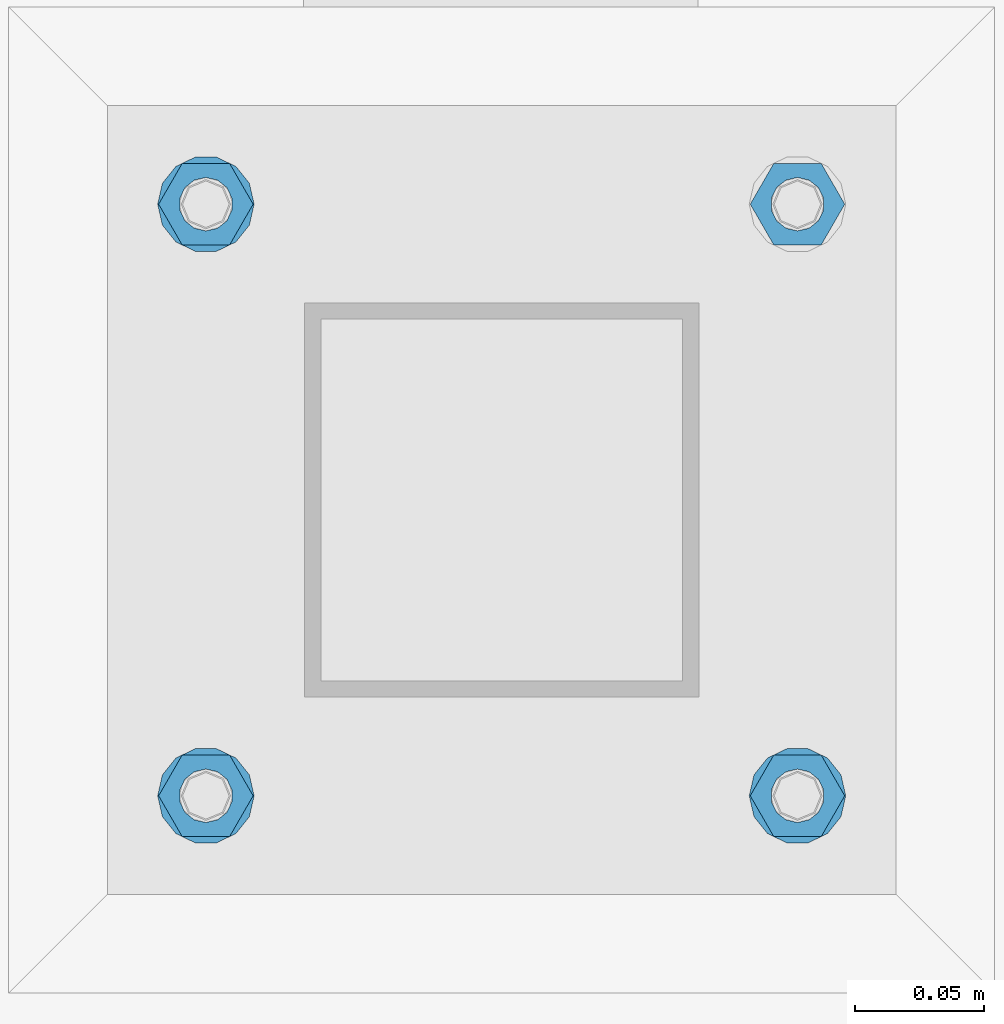
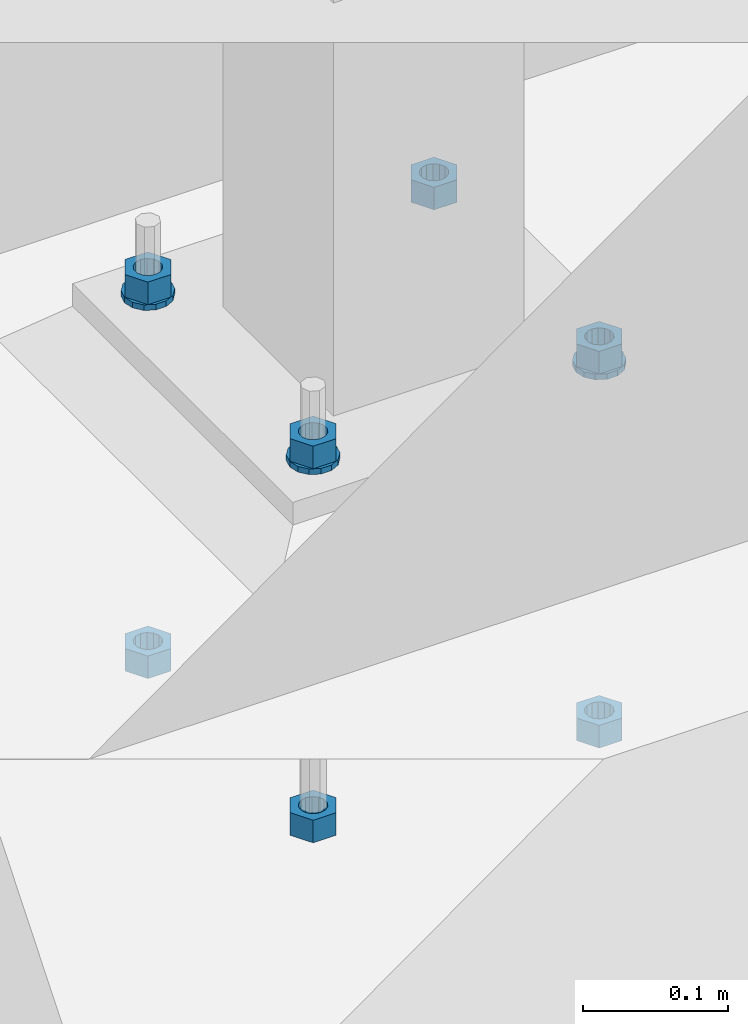
# One storey, part 957 of 1179: 10 beams, 1 element without a shape of its own.
"""IFC2X3 building model written with IfcOpenShell, lengths in millimetres."""

import ifcopenshell
import ifcopenshell.guid

model = None  # the IFC model being written
_history = None  # IfcOwnerHistory: only IFC2X3 demands one
_inside = {}  # id of a spatial element -> (the spatial element, [elements in it])
_under = {}  # id of a project, library or spatial element -> (it, [spatial elements below it])
_declared = {}  # id of a project -> (the project, [libraries it declares])
_typed = {}  # id of a type object -> (the type object, [elements of that type])
_made_of = {}  # id of a material, layer set ... -> (it, [elements and type objects made of it])


def new_model(schema):
    """Start an empty IFC model of exactly this schema.

    Asked for "IFC4X3", IfcOpenShell would pick the latest addendum, in which some entities
    have other attributes; the version numbers below select the first issue.
    IFC2X3 requires an IfcOwnerHistory on every rooted entity: one is made here for all.
    """
    global model, _history
    if schema == "IFC4X3":
        model = ifcopenshell.file(schema_version=(4, 3, 0, 0))
    else:
        model = ifcopenshell.file(schema=schema)
    _inside.clear()
    _under.clear()
    _declared.clear()
    _typed.clear()
    _made_of.clear()
    _history = None
    if model.schema == "IFC2X3":
        org = make("IfcOrganization", Name="unknown")
        user = make(
            "IfcPersonAndOrganization",
            ThePerson=make("IfcPerson", FamilyName="unknown"),
            TheOrganization=org,
        )
        app = make(
            "IfcApplication",
            ApplicationDeveloper=org,
            Version="unknown",
            ApplicationFullName="unknown",
            ApplicationIdentifier="unknown",
        )
        _history = make(
            "IfcOwnerHistory",
            OwningUser=user,
            OwningApplication=app,
            ChangeAction="ADDED",
            CreationDate=0,
        )
    return model


def make(cls, **values):
    """One entity of the class cls with the attributes given. An attribute that is None is left unset."""
    return model.create_entity(
        cls, **{name: value for name, value in values.items() if value is not None}
    )


def rooted(cls, **values):
    """An entity with a GlobalId (a new one), such as an element, a storey or a relation."""
    return make(cls, GlobalId=ifcopenshell.guid.new(), OwnerHistory=_history, **values)


def si_unit(unit_type, name, prefix=None):
    """IfcSIUnit, for example si_unit("LENGTHUNIT", "METRE", prefix="MILLI")."""
    return make("IfcSIUnit", UnitType=unit_type, Prefix=prefix, Name=name)


def assignment(units):
    """IfcUnitAssignment: the units of a project."""
    return None if units is None else make("IfcUnitAssignment", Units=units)


def point(xyz):
    """IfcCartesianPoint."""
    return None if xyz is None else make("IfcCartesianPoint", Coordinates=xyz)


def direction(xyz):
    """IfcDirection."""
    return None if xyz is None else make("IfcDirection", DirectionRatios=xyz)


def frame(location, z_axis=None, x_axis=None):
    """IfcAxis2Placement3D, a coordinate frame: its origin and axes. An axis left out is left unset."""
    return make(
        "IfcAxis2Placement3D",
        Location=point(location),
        Axis=direction(z_axis),
        RefDirection=direction(x_axis),
    )


def origin_with_axes():
    """The frame at (0, 0, 0) with the z axis (0, 0, 1) and the x axis (1, 0, 0) written out."""
    return frame((0.0, 0.0, 0.0), z_axis=(0.0, 0.0, 1.0), x_axis=(1.0, 0.0, 0.0))


def place(relative_to, where):
    """IfcLocalPlacement: puts the frame where relative to a parent placement (None: the world)."""
    return make(
        "IfcLocalPlacement", PlacementRelTo=relative_to, RelativePlacement=where
    )


def context(
    kind, dimensions, precision=None, world=None, true_north=None, identifier=None
):
    """IfcGeometricRepresentationContext, for example the 3D "Model" context."""
    return make(
        "IfcGeometricRepresentationContext",
        ContextIdentifier=identifier,
        ContextType=kind,
        CoordinateSpaceDimension=dimensions,
        Precision=precision,
        WorldCoordinateSystem=world,
        TrueNorth=true_north,
    )


def subcontext(parent, identifier, kind, view, scale=None):
    """IfcGeometricRepresentationSubContext, for example "Body" below "Model"."""
    return make(
        "IfcGeometricRepresentationSubContext",
        ContextIdentifier=identifier,
        ContextType=kind,
        ParentContext=parent,
        TargetScale=scale,
        TargetView=view,
    )


def project(units=None, contexts=None):
    """IfcProject with its units and contexts."""
    return rooted(
        "IfcProject",
        Name="project",
        RepresentationContexts=contexts,
        UnitsInContext=assignment(units),
    )


def spatial(cls, under=None, at=None, **own):
    """A site, building, storey or space (cls), placed at a placement, below another one or the project."""
    s = rooted(cls, ObjectPlacement=at, **own)
    if under is not None:
        _under.setdefault(under.id(), (under, []))[1].append(s)
    return s


def faces_of(points, faces, orient=None, outer=None):
    """IfcFace entities. A face is a list of loops; a loop is a list of indices into points, from 0.

    orient and outer hold one flag for each loop. By default every Orientation is true, the
    first loop of a face is its IfcFaceOuterBound and the others are IfcFaceBound.
    """
    made = []
    for i, loops in enumerate(faces):
        bounds = []
        for j, loop in enumerate(loops):
            is_outer = j == 0 if outer is None else outer[i][j]
            bounds.append(
                make(
                    "IfcFaceOuterBound" if is_outer else "IfcFaceBound",
                    Bound=make("IfcPolyLoop", Polygon=[points[k] for k in loop]),
                    Orientation=True if orient is None else orient[i][j],
                )
            )
        made.append(make("IfcFace", Bounds=bounds))
    return made


def faceted_brep(points, faces, orient=None, outer=None, voids=None):
    """IfcFacetedBrep: a solid bounded by flat faces; with voids (closed shells), ...WithVoids."""
    shared = [point(p) for p in points]
    hull = make("IfcClosedShell", CfsFaces=faces_of(shared, faces, orient, outer))
    if voids is None:
        return make("IfcFacetedBrep", Outer=hull)
    return make(
        "IfcFacetedBrepWithVoids",
        Outer=hull,
        Voids=[
            make(cls, CfsFaces=faces_of(shared, fs, o, b)) for cls, fs, o, b in voids
        ],
    )


def shape(context_of_items, identifier, shape_type, items):
    """IfcShapeRepresentation: the items that make up one representation, for example the "Body"."""
    return make(
        "IfcShapeRepresentation",
        ContextOfItems=context_of_items,
        RepresentationIdentifier=identifier,
        RepresentationType=shape_type,
        Items=items,
    )


def material(Name=None, Category=None):
    """IfcMaterial."""
    return make("IfcMaterial", Name=Name, Category=Category)


def made_of(thing, what):
    """Note that an element or type object is made of a material, layer set ...; save() writes the relation."""
    if what is not None:
        _made_of.setdefault(what.id(), (what, []))[1].append(thing)
    return thing


def type_object(cls, material=None, **own):
    """A type object (cls), such as IfcWallType, which elements share."""
    return made_of(rooted(cls, **own), material)


def element(
    cls,
    number,
    at=None,
    inside=None,
    cuts=None,
    type_object=None,
    material=None,
    context=None,
    identifier="Body",
    shape_type=None,
    held_by="IfcProductDefinitionShape",
    body=None,
    shapes=None,
    **own,
):
    """One element of the class cls, such as IfcWall. Its Tag is "e" and its number.

    at: its placement. inside: the storey or other place that contains it. cuts: it is an
    opening in that element (IfcRelVoidsElement). A single representation is given by context,
    identifier, shape_type and body (its items); several are given by shapes. held_by: the class
    of the entity that holds the representations. save() writes the other relations.
    """
    e = rooted(cls, Tag="e%d" % number, ObjectPlacement=at, **own)
    if body is not None:
        shapes = [shape(context, identifier, shape_type, body)]
    if shapes is not None:
        e.Representation = make(held_by, Representations=shapes)
    if inside is not None:
        _inside.setdefault(inside.id(), (inside, []))[1].append(e)
    if cuts is not None:
        rooted(
            "IfcRelVoidsElement", RelatingBuildingElement=cuts, RelatedOpeningElement=e
        )
    if type_object is not None:
        _typed.setdefault(type_object.id(), (type_object, []))[1].append(e)
    return made_of(e, material)


def aggregate(whole, parts):
    """IfcRelAggregates: a whole, such as a stair, and the parts it consists of."""
    return rooted("IfcRelAggregates", RelatingObject=whole, RelatedObjects=parts)


def save(model, path):
    """Write the relations noted so far, then the file.

    IfcRelAggregates (storeys below a building ...), IfcRelContainedInSpatialStructure (elements
    in a storey), IfcRelDefinesByType, IfcRelAssociatesMaterial and IfcRelDeclares: one each for
    every whole, place, type object, material and project.
    """
    for whole, parts in _under.values():
        aggregate(whole, parts)
    for where, things in _inside.values():
        rooted(
            "IfcRelContainedInSpatialStructure",
            RelatedElements=things,
            RelatingStructure=where,
        )
    for kind, things in _typed.values():
        rooted("IfcRelDefinesByType", RelatedObjects=things, RelatingType=kind)
    for what, things in _made_of.values():
        rooted("IfcRelAssociatesMaterial", RelatedObjects=things, RelatingMaterial=what)
    for by, libraries in _declared.values():
        rooted("IfcRelDeclares", RelatingContext=by, RelatedDefinitions=libraries)
    model.write(path)


model = new_model("IFC2X3")

# Units and contexts
model_context = context("Model", 3, precision=1e-05, world=origin_with_axes())
body_context = subcontext(model_context, "Body", "Model", "MODEL_VIEW")
ifc_project = project(units=[si_unit("LENGTHUNIT", "METRE", prefix="MILLI"), si_unit("AREAUNIT", "SQUARE_METRE"), si_unit("VOLUMEUNIT", "CUBIC_METRE"), si_unit("MASSUNIT", "GRAM", prefix="KILO"), si_unit("TIMEUNIT", "SECOND"), si_unit("PLANEANGLEUNIT", "RADIAN"), si_unit("SOLIDANGLEUNIT", "STERADIAN"), si_unit("THERMODYNAMICTEMPERATUREUNIT", "DEGREE_CELSIUS"), si_unit("LUMINOUSINTENSITYUNIT", "LUMEN")], contexts=[model_context])

# Site, building, storey
site_placement = place(None, origin_with_axes())
site = spatial("IfcSite", under=ifc_project, at=site_placement, CompositionType="ELEMENT")
building_placement = place(site_placement, origin_with_axes())
building = spatial("IfcBuilding", under=site, at=building_placement, Name="Undefined", CompositionType="ELEMENT")
storey_placement = place(building_placement, origin_with_axes())
storey = spatial("IfcBuildingStorey", under=building, at=storey_placement, Name="Undefined", CompositionType="ELEMENT", Elevation=0.0)

# Assembly, beams
assembly_placement = place(storey_placement, origin_with_axes())
assembly = element("IfcElementAssembly", 1, at=assembly_placement, inside=storey, Name="TEMPLATE", AssemblyPlace="NOTDEFINED", PredefinedType="RIGID_FRAME")
ifc_material = material(Name="STEEL/A36")
beam_type_1 = type_object("IfcBeamType", Name="3/4_HEAVY_HEX_NUT", PredefinedType="NOTDEFINED")
beam_1_placement = place(assembly_placement, frame((30111.7, 2120.9, -731.8375), z_axis=(0.0, -1.0, 0.0), x_axis=(0.0, 0.0, -1.0)))
beam_1 = element("IfcBeam", 2, at=beam_1_placement, type_object=beam_type_1, material=ifc_material, Name="NUT", ObjectType="3/4_HEAVY_HEX_NUT", context=body_context, shape_type="Brep", body=[
    faceted_brep([(0.0, -18.2600002288818, 0.0), (0.0, -9.13000011444092, -15.8100004196167), (19.0499999999865, -9.13000011444092, -15.8100004196167), (19.0499999999865, -18.2600002288818, 0.0), (0.0, 9.13000011444092, -15.8100004196167), (19.0499999999865, 9.13000011444092, -15.8100004196167), (0.0, 18.2600002288818, 0.0), (19.0499999999865, 18.2600002288818, 0.0), (0.0, 9.13000011444092, 15.8100004196167), (19.0499999999865, 9.13000011444092, 15.8100004196167), (0.0, -9.13000011444092, 15.8100004196167), (19.0499999999865, -9.13000011444092, 15.8100004196167), (0.0, 0.0, 10.3199996948242), (0.0, 4.47768005528246, 9.29799844179979), (19.0499999999865, 4.47768005528246, 9.29799844179979), (19.0499999999865, 0.0, 10.3199996948242), (0.0, 8.068500660474, 6.43441456490837), (19.0499999999865, 8.068500660474, 6.43441456490837), (0.0, 10.0612557561919, 2.29641597052068), (19.0499999999865, 10.0612557561919, 2.29641597052068), (0.0, 10.0612557561919, -2.29641597052068), (19.0499999999865, 10.0612557561919, -2.29641597052068), (0.0, 8.068500660474, -6.43441456490837), (19.0499999999865, 8.068500660474, -6.43441456490837), (0.0, 4.47768005528246, -9.29799844179979), (19.0499999999865, 4.47768005528246, -9.29799844179979), (0.0, 0.0, -10.3199996948242), (19.0499999999865, 0.0, -10.3199996948242), (0.0, -4.47768005528246, -9.29799844179979), (19.0499999999865, -4.47768005528246, -9.29799844179979), (0.0, -8.068500660474, -6.43441456490837), (19.0499999999865, -8.068500660474, -6.43441456490837), (0.0, -10.0612557561919, -2.29641597052068), (19.0499999999865, -10.0612557561919, -2.29641597052068), (0.0, -10.0612557561919, 2.29641597052068), (19.0499999999865, -10.0612557561919, 2.29641597052068), (0.0, -8.068500660474, 6.43441456490837), (19.0499999999865, -8.068500660474, 6.43441456490837), (0.0, -4.47768005528246, 9.29799844179979), (19.0499999999865, -4.47768005528246, 9.29799844179979)], [[[0, 1, 2, 3]], [[1, 4, 5, 2]], [[4, 6, 7, 5]], [[6, 8, 9, 7]], [[8, 10, 11, 9]], [[10, 0, 3, 11]], [[12, 13, 14, 15]], [[13, 16, 17, 14]], [[16, 18, 19, 17]], [[18, 20, 21, 19]], [[20, 22, 23, 21]], [[22, 24, 25, 23]], [[24, 26, 27, 25]], [[26, 28, 29, 27]], [[28, 30, 31, 29]], [[30, 32, 33, 31]], [[32, 34, 35, 33]], [[34, 36, 37, 35]], [[36, 38, 39, 37]], [[38, 12, 15, 39]], [[5, 7, 9, 11, 3, 2], [17, 19, 21, 23, 25, 27, 29, 31, 33, 35, 37, 39, 15, 14]], [[10, 8, 6, 4, 1, 0], [38, 36, 34, 32, 30, 28, 26, 24, 22, 20, 18, 16, 13, 12]]]),
])
beam_2_placement = place(assembly_placement, frame((30111.7, 2120.9, -1047.75), z_axis=(0.0, -1.0, 0.0), x_axis=(0.0, 0.0, -1.0)))
beam_2 = element("IfcBeam", 3, at=beam_2_placement, type_object=beam_type_1, material=ifc_material, Name="NUT", ObjectType="3/4_HEAVY_HEX_NUT", context=body_context, shape_type="Brep", body=[
    faceted_brep([(0.0, -18.2600002288818, 0.0), (0.0, -9.13000011444092, -15.8100004196167), (19.0499999999865, -9.13000011444092, -15.8100004196167), (19.0499999999865, -18.2600002288818, 0.0), (0.0, 9.13000011444092, -15.8100004196167), (19.0499999999865, 9.13000011444092, -15.8100004196167), (0.0, 18.2600002288818, 0.0), (19.0499999999865, 18.2600002288818, 0.0), (0.0, 9.13000011444092, 15.8100004196167), (19.0499999999865, 9.13000011444092, 15.8100004196167), (0.0, -9.13000011444092, 15.8100004196167), (19.0499999999865, -9.13000011444092, 15.8100004196167), (0.0, 0.0, 10.3199996948242), (0.0, 4.47768005528246, 9.29799844179979), (19.0499999999865, 4.47768005528246, 9.29799844179979), (19.0499999999865, 0.0, 10.3199996948242), (0.0, 8.068500660474, 6.43441456490837), (19.0499999999865, 8.068500660474, 6.43441456490837), (0.0, 10.0612557561919, 2.29641597052068), (19.0499999999865, 10.0612557561919, 2.29641597052068), (0.0, 10.0612557561919, -2.29641597052068), (19.0499999999865, 10.0612557561919, -2.29641597052068), (0.0, 8.068500660474, -6.43441456490837), (19.0499999999865, 8.068500660474, -6.43441456490837), (0.0, 4.47768005528246, -9.29799844179979), (19.0499999999865, 4.47768005528246, -9.29799844179979), (0.0, 0.0, -10.3199996948242), (19.0499999999865, 0.0, -10.3199996948242), (0.0, -4.47768005528246, -9.29799844179979), (19.0499999999865, -4.47768005528246, -9.29799844179979), (0.0, -8.068500660474, -6.43441456490837), (19.0499999999865, -8.068500660474, -6.43441456490837), (0.0, -10.0612557561919, -2.29641597052068), (19.0499999999865, -10.0612557561919, -2.29641597052068), (0.0, -10.0612557561919, 2.29641597052068), (19.0499999999865, -10.0612557561919, 2.29641597052068), (0.0, -8.068500660474, 6.43441456490837), (19.0499999999865, -8.068500660474, 6.43441456490837), (0.0, -4.47768005528246, 9.29799844179979), (19.0499999999865, -4.47768005528246, 9.29799844179979)], [[[0, 1, 2, 3]], [[1, 4, 5, 2]], [[4, 6, 7, 5]], [[6, 8, 9, 7]], [[8, 10, 11, 9]], [[10, 0, 3, 11]], [[12, 13, 14, 15]], [[13, 16, 17, 14]], [[16, 18, 19, 17]], [[18, 20, 21, 19]], [[20, 22, 23, 21]], [[22, 24, 25, 23]], [[24, 26, 27, 25]], [[26, 28, 29, 27]], [[28, 30, 31, 29]], [[30, 32, 33, 31]], [[32, 34, 35, 33]], [[34, 36, 37, 35]], [[36, 38, 39, 37]], [[38, 12, 15, 39]], [[5, 7, 9, 11, 3, 2], [17, 19, 21, 23, 25, 27, 29, 31, 33, 35, 37, 39, 15, 14]], [[10, 8, 6, 4, 1, 0], [38, 36, 34, 32, 30, 28, 26, 24, 22, 20, 18, 16, 13, 12]]]),
])
beam_3_placement = place(assembly_placement, frame((30340.3, 2120.9, -731.8375), z_axis=(0.0, 1.0, 0.0), x_axis=(0.0, 0.0, -1.0)))
beam_3 = element("IfcBeam", 4, at=beam_3_placement, type_object=beam_type_1, material=ifc_material, Name="NUT", ObjectType="3/4_HEAVY_HEX_NUT", context=body_context, shape_type="Brep", body=[
    faceted_brep([(0.0, -18.2600002288818, 0.0), (0.0, -9.13000011444092, -15.8100004196167), (19.0499999999865, -9.13000011444092, -15.8100004196167), (19.0499999999865, -18.2600002288818, 0.0), (0.0, 9.13000011444092, -15.8100004196167), (19.0499999999865, 9.13000011444092, -15.8100004196167), (0.0, 18.2600002288818, 0.0), (19.0499999999865, 18.2600002288818, 0.0), (0.0, 9.13000011444092, 15.8100004196167), (19.0499999999865, 9.13000011444092, 15.8100004196167), (0.0, -9.13000011444092, 15.8100004196167), (19.0499999999865, -9.13000011444092, 15.8100004196167), (0.0, 0.0, 10.3199996948242), (0.0, 4.47768005528246, 9.29799844179979), (19.0499999999865, 4.47768005528246, 9.29799844179979), (19.0499999999865, 0.0, 10.3199996948242), (0.0, 8.068500660474, 6.43441456490837), (19.0499999999865, 8.068500660474, 6.43441456490837), (0.0, 10.0612557561919, 2.29641597052068), (19.0499999999865, 10.0612557561919, 2.29641597052068), (0.0, 10.0612557561919, -2.29641597052068), (19.0499999999865, 10.0612557561919, -2.29641597052068), (0.0, 8.068500660474, -6.43441456490837), (19.0499999999865, 8.068500660474, -6.43441456490837), (0.0, 4.47768005528246, -9.29799844179979), (19.0499999999865, 4.47768005528246, -9.29799844179979), (0.0, 0.0, -10.3199996948242), (19.0499999999865, 0.0, -10.3199996948242), (0.0, -4.47768005528246, -9.29799844179979), (19.0499999999865, -4.47768005528246, -9.29799844179979), (0.0, -8.068500660474, -6.43441456490837), (19.0499999999865, -8.068500660474, -6.43441456490837), (0.0, -10.0612557561919, -2.29641597052068), (19.0499999999865, -10.0612557561919, -2.29641597052068), (0.0, -10.0612557561919, 2.29641597052068), (19.0499999999865, -10.0612557561919, 2.29641597052068), (0.0, -8.068500660474, 6.43441456490837), (19.0499999999865, -8.068500660474, 6.43441456490837), (0.0, -4.47768005528246, 9.29799844179979), (19.0499999999865, -4.47768005528246, 9.29799844179979)], [[[0, 1, 2, 3]], [[1, 4, 5, 2]], [[4, 6, 7, 5]], [[6, 8, 9, 7]], [[8, 10, 11, 9]], [[10, 0, 3, 11]], [[12, 13, 14, 15]], [[13, 16, 17, 14]], [[16, 18, 19, 17]], [[18, 20, 21, 19]], [[20, 22, 23, 21]], [[22, 24, 25, 23]], [[24, 26, 27, 25]], [[26, 28, 29, 27]], [[28, 30, 31, 29]], [[30, 32, 33, 31]], [[32, 34, 35, 33]], [[34, 36, 37, 35]], [[36, 38, 39, 37]], [[38, 12, 15, 39]], [[5, 7, 9, 11, 3, 2], [17, 19, 21, 23, 25, 27, 29, 31, 33, 35, 37, 39, 15, 14]], [[10, 8, 6, 4, 1, 0], [38, 36, 34, 32, 30, 28, 26, 24, 22, 20, 18, 16, 13, 12]]]),
])
beam_4_placement = place(assembly_placement, frame((30340.3, 2120.9, -1047.75), z_axis=(0.0, 1.0, 0.0), x_axis=(0.0, 0.0, -1.0)))
beam_4 = element("IfcBeam", 5, at=beam_4_placement, type_object=beam_type_1, material=ifc_material, Name="NUT", ObjectType="3/4_HEAVY_HEX_NUT", context=body_context, shape_type="Brep", body=[
    faceted_brep([(0.0, -18.2600002288818, 0.0), (0.0, -9.13000011444092, -15.8100004196167), (19.0499999999865, -9.13000011444092, -15.8100004196167), (19.0499999999865, -18.2600002288818, 0.0), (0.0, 9.13000011444092, -15.8100004196167), (19.0499999999865, 9.13000011444092, -15.8100004196167), (0.0, 18.2600002288818, 0.0), (19.0499999999865, 18.2600002288818, 0.0), (0.0, 9.13000011444092, 15.8100004196167), (19.0499999999865, 9.13000011444092, 15.8100004196167), (0.0, -9.13000011444092, 15.8100004196167), (19.0499999999865, -9.13000011444092, 15.8100004196167), (0.0, 0.0, 10.3199996948242), (0.0, 4.47768005528246, 9.29799844179979), (19.0499999999865, 4.47768005528246, 9.29799844179979), (19.0499999999865, 0.0, 10.3199996948242), (0.0, 8.068500660474, 6.43441456490837), (19.0499999999865, 8.068500660474, 6.43441456490837), (0.0, 10.0612557561919, 2.29641597052068), (19.0499999999865, 10.0612557561919, 2.29641597052068), (0.0, 10.0612557561919, -2.29641597052068), (19.0499999999865, 10.0612557561919, -2.29641597052068), (0.0, 8.068500660474, -6.43441456490837), (19.0499999999865, 8.068500660474, -6.43441456490837), (0.0, 4.47768005528246, -9.29799844179979), (19.0499999999865, 4.47768005528246, -9.29799844179979), (0.0, 0.0, -10.3199996948242), (19.0499999999865, 0.0, -10.3199996948242), (0.0, -4.47768005528246, -9.29799844179979), (19.0499999999865, -4.47768005528246, -9.29799844179979), (0.0, -8.068500660474, -6.43441456490837), (19.0499999999865, -8.068500660474, -6.43441456490837), (0.0, -10.0612557561919, -2.29641597052068), (19.0499999999865, -10.0612557561919, -2.29641597052068), (0.0, -10.0612557561919, 2.29641597052068), (19.0499999999865, -10.0612557561919, 2.29641597052068), (0.0, -8.068500660474, 6.43441456490837), (19.0499999999865, -8.068500660474, 6.43441456490837), (0.0, -4.47768005528246, 9.29799844179979), (19.0499999999865, -4.47768005528246, 9.29799844179979)], [[[0, 1, 2, 3]], [[1, 4, 5, 2]], [[4, 6, 7, 5]], [[6, 8, 9, 7]], [[8, 10, 11, 9]], [[10, 0, 3, 11]], [[12, 13, 14, 15]], [[13, 16, 17, 14]], [[16, 18, 19, 17]], [[18, 20, 21, 19]], [[20, 22, 23, 21]], [[22, 24, 25, 23]], [[24, 26, 27, 25]], [[26, 28, 29, 27]], [[28, 30, 31, 29]], [[30, 32, 33, 31]], [[32, 34, 35, 33]], [[34, 36, 37, 35]], [[36, 38, 39, 37]], [[38, 12, 15, 39]], [[5, 7, 9, 11, 3, 2], [17, 19, 21, 23, 25, 27, 29, 31, 33, 35, 37, 39, 15, 14]], [[10, 8, 6, 4, 1, 0], [38, 36, 34, 32, 30, 28, 26, 24, 22, 20, 18, 16, 13, 12]]]),
])
beam_5_placement = place(assembly_placement, frame((30111.7, 2349.5, -731.8375), z_axis=(0.0, -1.0, 0.0), x_axis=(0.0, 0.0, -1.0)))
beam_5 = element("IfcBeam", 6, at=beam_5_placement, type_object=beam_type_1, material=ifc_material, Name="NUT", ObjectType="3/4_HEAVY_HEX_NUT", context=body_context, shape_type="Brep", body=[
    faceted_brep([(0.0, -18.2600002288818, 0.0), (0.0, -9.13000011444092, -15.8100004196167), (19.0499999999865, -9.13000011444092, -15.8100004196167), (19.0499999999865, -18.2600002288818, 0.0), (0.0, 9.13000011444092, -15.8100004196167), (19.0499999999865, 9.13000011444092, -15.8100004196167), (0.0, 18.2600002288818, 0.0), (19.0499999999865, 18.2600002288818, 0.0), (0.0, 9.13000011444092, 15.8100004196167), (19.0499999999865, 9.13000011444092, 15.8100004196167), (0.0, -9.13000011444092, 15.8100004196167), (19.0499999999865, -9.13000011444092, 15.8100004196167), (0.0, 0.0, 10.3199996948242), (0.0, 4.47768005528246, 9.29799844179979), (19.0499999999865, 4.47768005528246, 9.29799844179979), (19.0499999999865, 0.0, 10.3199996948242), (0.0, 8.068500660474, 6.43441456490837), (19.0499999999865, 8.068500660474, 6.43441456490837), (0.0, 10.0612557561919, 2.29641597052068), (19.0499999999865, 10.0612557561919, 2.29641597052068), (0.0, 10.0612557561919, -2.29641597052068), (19.0499999999865, 10.0612557561919, -2.29641597052068), (0.0, 8.068500660474, -6.43441456490837), (19.0499999999865, 8.068500660474, -6.43441456490837), (0.0, 4.47768005528246, -9.29799844179979), (19.0499999999865, 4.47768005528246, -9.29799844179979), (0.0, 0.0, -10.3199996948242), (19.0499999999865, 0.0, -10.3199996948242), (0.0, -4.47768005528246, -9.29799844179979), (19.0499999999865, -4.47768005528246, -9.29799844179979), (0.0, -8.068500660474, -6.43441456490837), (19.0499999999865, -8.068500660474, -6.43441456490837), (0.0, -10.0612557561919, -2.29641597052068), (19.0499999999865, -10.0612557561919, -2.29641597052068), (0.0, -10.0612557561919, 2.29641597052068), (19.0499999999865, -10.0612557561919, 2.29641597052068), (0.0, -8.068500660474, 6.43441456490837), (19.0499999999865, -8.068500660474, 6.43441456490837), (0.0, -4.47768005528246, 9.29799844179979), (19.0499999999865, -4.47768005528246, 9.29799844179979)], [[[0, 1, 2, 3]], [[1, 4, 5, 2]], [[4, 6, 7, 5]], [[6, 8, 9, 7]], [[8, 10, 11, 9]], [[10, 0, 3, 11]], [[12, 13, 14, 15]], [[13, 16, 17, 14]], [[16, 18, 19, 17]], [[18, 20, 21, 19]], [[20, 22, 23, 21]], [[22, 24, 25, 23]], [[24, 26, 27, 25]], [[26, 28, 29, 27]], [[28, 30, 31, 29]], [[30, 32, 33, 31]], [[32, 34, 35, 33]], [[34, 36, 37, 35]], [[36, 38, 39, 37]], [[38, 12, 15, 39]], [[5, 7, 9, 11, 3, 2], [17, 19, 21, 23, 25, 27, 29, 31, 33, 35, 37, 39, 15, 14]], [[10, 8, 6, 4, 1, 0], [38, 36, 34, 32, 30, 28, 26, 24, 22, 20, 18, 16, 13, 12]]]),
])
beam_6_placement = place(assembly_placement, frame((30111.7, 2349.5, -1047.75), z_axis=(0.0, -1.0, 0.0), x_axis=(0.0, 0.0, -1.0)))
beam_6 = element("IfcBeam", 7, at=beam_6_placement, type_object=beam_type_1, material=ifc_material, Name="NUT", ObjectType="3/4_HEAVY_HEX_NUT", context=body_context, shape_type="Brep", body=[
    faceted_brep([(0.0, -18.2600002288818, 0.0), (0.0, -9.13000011444092, -15.8100004196167), (19.0499999999865, -9.13000011444092, -15.8100004196167), (19.0499999999865, -18.2600002288818, 0.0), (0.0, 9.13000011444092, -15.8100004196167), (19.0499999999865, 9.13000011444092, -15.8100004196167), (0.0, 18.2600002288818, 0.0), (19.0499999999865, 18.2600002288818, 0.0), (0.0, 9.13000011444092, 15.8100004196167), (19.0499999999865, 9.13000011444092, 15.8100004196167), (0.0, -9.13000011444092, 15.8100004196167), (19.0499999999865, -9.13000011444092, 15.8100004196167), (0.0, 0.0, 10.3199996948242), (0.0, 4.47768005528246, 9.29799844179979), (19.0499999999865, 4.47768005528246, 9.29799844179979), (19.0499999999865, 0.0, 10.3199996948242), (0.0, 8.068500660474, 6.43441456490837), (19.0499999999865, 8.068500660474, 6.43441456490837), (0.0, 10.0612557561919, 2.29641597052068), (19.0499999999865, 10.0612557561919, 2.29641597052068), (0.0, 10.0612557561919, -2.29641597052068), (19.0499999999865, 10.0612557561919, -2.29641597052068), (0.0, 8.068500660474, -6.43441456490837), (19.0499999999865, 8.068500660474, -6.43441456490837), (0.0, 4.47768005528246, -9.29799844179979), (19.0499999999865, 4.47768005528246, -9.29799844179979), (0.0, 0.0, -10.3199996948242), (19.0499999999865, 0.0, -10.3199996948242), (0.0, -4.47768005528246, -9.29799844179979), (19.0499999999865, -4.47768005528246, -9.29799844179979), (0.0, -8.068500660474, -6.43441456490837), (19.0499999999865, -8.068500660474, -6.43441456490837), (0.0, -10.0612557561919, -2.29641597052068), (19.0499999999865, -10.0612557561919, -2.29641597052068), (0.0, -10.0612557561919, 2.29641597052068), (19.0499999999865, -10.0612557561919, 2.29641597052068), (0.0, -8.068500660474, 6.43441456490837), (19.0499999999865, -8.068500660474, 6.43441456490837), (0.0, -4.47768005528246, 9.29799844179979), (19.0499999999865, -4.47768005528246, 9.29799844179979)], [[[0, 1, 2, 3]], [[1, 4, 5, 2]], [[4, 6, 7, 5]], [[6, 8, 9, 7]], [[8, 10, 11, 9]], [[10, 0, 3, 11]], [[12, 13, 14, 15]], [[13, 16, 17, 14]], [[16, 18, 19, 17]], [[18, 20, 21, 19]], [[20, 22, 23, 21]], [[22, 24, 25, 23]], [[24, 26, 27, 25]], [[26, 28, 29, 27]], [[28, 30, 31, 29]], [[30, 32, 33, 31]], [[32, 34, 35, 33]], [[34, 36, 37, 35]], [[36, 38, 39, 37]], [[38, 12, 15, 39]], [[5, 7, 9, 11, 3, 2], [17, 19, 21, 23, 25, 27, 29, 31, 33, 35, 37, 39, 15, 14]], [[10, 8, 6, 4, 1, 0], [38, 36, 34, 32, 30, 28, 26, 24, 22, 20, 18, 16, 13, 12]]]),
])
beam_7_placement = place(assembly_placement, frame((30340.3, 2349.5, -731.8375), z_axis=(0.0, 1.0, 0.0), x_axis=(0.0, 0.0, -1.0)))
beam_7 = element("IfcBeam", 8, at=beam_7_placement, type_object=beam_type_1, material=ifc_material, Name="NUT", ObjectType="3/4_HEAVY_HEX_NUT", context=body_context, shape_type="Brep", body=[
    faceted_brep([(0.0, -18.2600002288818, 0.0), (0.0, -9.13000011444092, -15.8100004196167), (19.0499999999865, -9.13000011444092, -15.8100004196167), (19.0499999999865, -18.2600002288818, 0.0), (0.0, 9.13000011444092, -15.8100004196167), (19.0499999999865, 9.13000011444092, -15.8100004196167), (0.0, 18.2600002288818, 0.0), (19.0499999999865, 18.2600002288818, 0.0), (0.0, 9.13000011444092, 15.8100004196167), (19.0499999999865, 9.13000011444092, 15.8100004196167), (0.0, -9.13000011444092, 15.8100004196167), (19.0499999999865, -9.13000011444092, 15.8100004196167), (0.0, 0.0, 10.3199996948242), (0.0, 4.47768005528246, 9.29799844179979), (19.0499999999865, 4.47768005528246, 9.29799844179979), (19.0499999999865, 0.0, 10.3199996948242), (0.0, 8.068500660474, 6.43441456490837), (19.0499999999865, 8.068500660474, 6.43441456490837), (0.0, 10.0612557561919, 2.29641597052068), (19.0499999999865, 10.0612557561919, 2.29641597052068), (0.0, 10.0612557561919, -2.29641597052068), (19.0499999999865, 10.0612557561919, -2.29641597052068), (0.0, 8.068500660474, -6.43441456490837), (19.0499999999865, 8.068500660474, -6.43441456490837), (0.0, 4.47768005528246, -9.29799844179979), (19.0499999999865, 4.47768005528246, -9.29799844179979), (0.0, 0.0, -10.3199996948242), (19.0499999999865, 0.0, -10.3199996948242), (0.0, -4.47768005528246, -9.29799844179979), (19.0499999999865, -4.47768005528246, -9.29799844179979), (0.0, -8.068500660474, -6.43441456490837), (19.0499999999865, -8.068500660474, -6.43441456490837), (0.0, -10.0612557561919, -2.29641597052068), (19.0499999999865, -10.0612557561919, -2.29641597052068), (0.0, -10.0612557561919, 2.29641597052068), (19.0499999999865, -10.0612557561919, 2.29641597052068), (0.0, -8.068500660474, 6.43441456490837), (19.0499999999865, -8.068500660474, 6.43441456490837), (0.0, -4.47768005528246, 9.29799844179979), (19.0499999999865, -4.47768005528246, 9.29799844179979)], [[[0, 1, 2, 3]], [[1, 4, 5, 2]], [[4, 6, 7, 5]], [[6, 8, 9, 7]], [[8, 10, 11, 9]], [[10, 0, 3, 11]], [[12, 13, 14, 15]], [[13, 16, 17, 14]], [[16, 18, 19, 17]], [[18, 20, 21, 19]], [[20, 22, 23, 21]], [[22, 24, 25, 23]], [[24, 26, 27, 25]], [[26, 28, 29, 27]], [[28, 30, 31, 29]], [[30, 32, 33, 31]], [[32, 34, 35, 33]], [[34, 36, 37, 35]], [[36, 38, 39, 37]], [[38, 12, 15, 39]], [[5, 7, 9, 11, 3, 2], [17, 19, 21, 23, 25, 27, 29, 31, 33, 35, 37, 39, 15, 14]], [[10, 8, 6, 4, 1, 0], [38, 36, 34, 32, 30, 28, 26, 24, 22, 20, 18, 16, 13, 12]]]),
])
beam_type_2 = type_object("IfcBeamType", Name="3/4_WASHER", PredefinedType="NOTDEFINED")
beam_8_placement = place(assembly_placement, frame((30111.7, 2120.9, -750.8875), z_axis=(0.0, -1.0, 0.0), x_axis=(0.0, 0.0, -1.0)))
beam_8 = element("IfcBeam", 9, at=beam_8_placement, type_object=beam_type_2, material=ifc_material, Name="WASHER", ObjectType="3/4_WASHER", context=body_context, shape_type="Brep", body=[
    faceted_brep([(0.0, -18.6499996185303, 0.0), (0.0, -16.8030690426895, -8.09193156902893), (4.76249999999993, -16.8030690426895, -8.09193156902893), (4.76249999999993, -18.6499996185303, 0.0), (0.0, -11.6280845668225, -14.5811568497838), (4.76249999999993, -11.6280845668225, -14.5811568497838), (0.0, -4.15001533339819, -18.1824051902859), (4.76249999999993, -4.15001533339819, -18.1824051902859), (0.0, 4.15001533339819, -18.1824051902859), (4.76249999999993, 4.15001533339819, -18.1824051902859), (0.0, 11.6280845668225, -14.5811568497838), (4.76249999999993, 11.6280845668225, -14.5811568497838), (0.0, 16.8030690426895, -8.09193156902893), (4.76249999999993, 16.8030690426895, -8.09193156902893), (0.0, 18.6499996185303, 0.0), (4.76249999999993, 18.6499996185303, 0.0), (0.0, 16.8030690426895, 8.09193156902893), (4.76249999999993, 16.8030690426895, 8.09193156902893), (0.0, 11.6280845668225, 14.5811568497838), (4.76249999999993, 11.6280845668225, 14.5811568497838), (0.0, 4.15001533339819, 18.1824051902859), (4.76249999999993, 4.15001533339819, 18.1824051902859), (0.0, -4.15001533339819, 18.1824051902859), (4.76249999999993, -4.15001533339819, 18.1824051902859), (0.0, -11.6280845668225, 14.5811568497838), (4.76249999999993, -11.6280845668225, 14.5811568497838), (0.0, -16.8030690426895, 8.09193156902893), (4.76249999999993, -16.8030690426895, 8.09193156902893), (0.0, 0.0, 10.3199996948242), (0.0, 4.47768005528246, 9.29799844179979), (4.76249999999993, 4.47768005527905, 9.29799844179888), (4.76249999999993, 0.0, 10.3199996948242), (0.0, 8.068500660474, 6.43441456490837), (4.76249999999993, 8.06850066047627, 6.43441456490837), (0.0, 10.0612557561919, 2.29641597052068), (4.76249999999993, 10.0612557561908, 2.29641597052114), (0.0, 10.0612557561919, -2.29641597052068), (4.76249999999993, 10.0612557561908, -2.29641597052114), (0.0, 8.068500660474, -6.43441456490837), (4.76249999999993, 8.06850066047627, -6.43441456490791), (0.0, 4.47768005528246, -9.29799844179979), (4.76249999999993, 4.47768005527905, -9.29799844179888), (0.0, 0.0, -10.3199996948242), (4.76249999999993, 0.0, -10.3199996948242), (0.0, -4.47768005528246, -9.29799844179979), (4.76249999999993, -4.47768005527905, -9.29799844179888), (0.0, -8.068500660474, -6.43441456490837), (4.76249999999993, -8.06850066047627, -6.43441456490837), (0.0, -10.0612557561919, -2.29641597052068), (4.76249999999993, -10.0612557561908, -2.29641597052114), (0.0, -10.0612557561919, 2.29641597052068), (4.76249999999993, -10.0612557561908, 2.29641597052114), (0.0, -8.068500660474, 6.43441456490837), (4.76249999999993, -8.06850066047627, 6.43441456490791), (0.0, -4.47768005528246, 9.29799844179979), (4.76249999999993, -4.47768005527905, 9.29799844179888)], [[[0, 1, 2, 3]], [[1, 4, 5, 2]], [[4, 6, 7, 5]], [[6, 8, 9, 7]], [[8, 10, 11, 9]], [[10, 12, 13, 11]], [[12, 14, 15, 13]], [[14, 16, 17, 15]], [[16, 18, 19, 17]], [[18, 20, 21, 19]], [[20, 22, 23, 21]], [[22, 24, 25, 23]], [[24, 26, 27, 25]], [[26, 0, 3, 27]], [[28, 29, 30, 31]], [[29, 32, 33, 30]], [[32, 34, 35, 33]], [[34, 36, 37, 35]], [[36, 38, 39, 37]], [[38, 40, 41, 39]], [[40, 42, 43, 41]], [[42, 44, 45, 43]], [[44, 46, 47, 45]], [[46, 48, 49, 47]], [[48, 50, 51, 49]], [[50, 52, 53, 51]], [[52, 54, 55, 53]], [[54, 28, 31, 55]], [[5, 7, 9, 11, 13, 15, 17, 19, 21, 23, 25, 27, 3, 2], [33, 35, 37, 39, 41, 43, 45, 47, 49, 51, 53, 55, 31, 30]], [[26, 24, 22, 20, 18, 16, 14, 12, 10, 8, 6, 4, 1, 0], [54, 52, 50, 48, 46, 44, 42, 40, 38, 36, 34, 32, 29, 28]]]),
])
beam_9_placement = place(assembly_placement, frame((30340.3, 2120.9, -750.8875), z_axis=(0.0, 1.0, 0.0), x_axis=(0.0, 0.0, -1.0)))
beam_9 = element("IfcBeam", 10, at=beam_9_placement, type_object=beam_type_2, material=ifc_material, Name="WASHER", ObjectType="3/4_WASHER", context=body_context, shape_type="Brep", body=[
    faceted_brep([(0.0, -18.6499996185303, 0.0), (0.0, -16.8030690426895, -8.09193156902893), (4.76249999999993, -16.8030690426895, -8.09193156902893), (4.76249999999993, -18.6499996185303, 0.0), (0.0, -11.6280845668225, -14.5811568497838), (4.76249999999993, -11.6280845668225, -14.5811568497838), (0.0, -4.15001533339819, -18.1824051902859), (4.76249999999993, -4.15001533339819, -18.1824051902859), (0.0, 4.15001533339819, -18.1824051902859), (4.76249999999993, 4.15001533339819, -18.1824051902859), (0.0, 11.6280845668225, -14.5811568497838), (4.76249999999993, 11.6280845668225, -14.5811568497838), (0.0, 16.8030690426895, -8.09193156902893), (4.76249999999993, 16.8030690426895, -8.09193156902893), (0.0, 18.6499996185303, 0.0), (4.76249999999993, 18.6499996185303, 0.0), (0.0, 16.8030690426895, 8.09193156902893), (4.76249999999993, 16.8030690426895, 8.09193156902893), (0.0, 11.6280845668225, 14.5811568497838), (4.76249999999993, 11.6280845668225, 14.5811568497838), (0.0, 4.15001533339819, 18.1824051902859), (4.76249999999993, 4.15001533339819, 18.1824051902859), (0.0, -4.15001533339819, 18.1824051902859), (4.76249999999993, -4.15001533339819, 18.1824051902859), (0.0, -11.6280845668225, 14.5811568497838), (4.76249999999993, -11.6280845668225, 14.5811568497838), (0.0, -16.8030690426895, 8.09193156902893), (4.76249999999993, -16.8030690426895, 8.09193156902893), (0.0, 0.0, 10.3199996948242), (0.0, 4.47768005528246, 9.29799844179979), (4.76249999999993, 4.47768005527905, 9.29799844179888), (4.76249999999993, 0.0, 10.3199996948242), (0.0, 8.068500660474, 6.43441456490837), (4.76249999999993, 8.06850066047627, 6.43441456490837), (0.0, 10.0612557561919, 2.29641597052068), (4.76249999999993, 10.0612557561908, 2.29641597052114), (0.0, 10.0612557561919, -2.29641597052068), (4.76249999999993, 10.0612557561908, -2.29641597052114), (0.0, 8.068500660474, -6.43441456490837), (4.76249999999993, 8.06850066047627, -6.43441456490791), (0.0, 4.47768005528246, -9.29799844179979), (4.76249999999993, 4.47768005527905, -9.29799844179888), (0.0, 0.0, -10.3199996948242), (4.76249999999993, 0.0, -10.3199996948242), (0.0, -4.47768005528246, -9.29799844179979), (4.76249999999993, -4.47768005527905, -9.29799844179888), (0.0, -8.068500660474, -6.43441456490837), (4.76249999999993, -8.06850066047627, -6.43441456490837), (0.0, -10.0612557561919, -2.29641597052068), (4.76249999999993, -10.0612557561908, -2.29641597052114), (0.0, -10.0612557561919, 2.29641597052068), (4.76249999999993, -10.0612557561908, 2.29641597052114), (0.0, -8.068500660474, 6.43441456490837), (4.76249999999993, -8.06850066047627, 6.43441456490791), (0.0, -4.47768005528246, 9.29799844179979), (4.76249999999993, -4.47768005527905, 9.29799844179888)], [[[0, 1, 2, 3]], [[1, 4, 5, 2]], [[4, 6, 7, 5]], [[6, 8, 9, 7]], [[8, 10, 11, 9]], [[10, 12, 13, 11]], [[12, 14, 15, 13]], [[14, 16, 17, 15]], [[16, 18, 19, 17]], [[18, 20, 21, 19]], [[20, 22, 23, 21]], [[22, 24, 25, 23]], [[24, 26, 27, 25]], [[26, 0, 3, 27]], [[28, 29, 30, 31]], [[29, 32, 33, 30]], [[32, 34, 35, 33]], [[34, 36, 37, 35]], [[36, 38, 39, 37]], [[38, 40, 41, 39]], [[40, 42, 43, 41]], [[42, 44, 45, 43]], [[44, 46, 47, 45]], [[46, 48, 49, 47]], [[48, 50, 51, 49]], [[50, 52, 53, 51]], [[52, 54, 55, 53]], [[54, 28, 31, 55]], [[5, 7, 9, 11, 13, 15, 17, 19, 21, 23, 25, 27, 3, 2], [33, 35, 37, 39, 41, 43, 45, 47, 49, 51, 53, 55, 31, 30]], [[26, 24, 22, 20, 18, 16, 14, 12, 10, 8, 6, 4, 1, 0], [54, 52, 50, 48, 46, 44, 42, 40, 38, 36, 34, 32, 29, 28]]]),
])
beam_10_placement = place(assembly_placement, frame((30111.7, 2349.5, -750.8875), z_axis=(0.0, -1.0, 0.0), x_axis=(0.0, 0.0, -1.0)))
beam_10 = element("IfcBeam", 11, at=beam_10_placement, type_object=beam_type_2, material=ifc_material, Name="WASHER", ObjectType="3/4_WASHER", context=body_context, shape_type="Brep", body=[
    faceted_brep([(0.0, -18.6499996185303, 0.0), (0.0, -16.8030690426895, -8.09193156902893), (4.76249999999993, -16.8030690426895, -8.09193156902893), (4.76249999999993, -18.6499996185303, 0.0), (0.0, -11.6280845668225, -14.5811568497838), (4.76249999999993, -11.6280845668225, -14.5811568497838), (0.0, -4.15001533339819, -18.1824051902859), (4.76249999999993, -4.15001533339819, -18.1824051902859), (0.0, 4.15001533339819, -18.1824051902859), (4.76249999999993, 4.15001533339819, -18.1824051902859), (0.0, 11.6280845668225, -14.5811568497838), (4.76249999999993, 11.6280845668225, -14.5811568497838), (0.0, 16.8030690426895, -8.09193156902893), (4.76249999999993, 16.8030690426895, -8.09193156902893), (0.0, 18.6499996185303, 0.0), (4.76249999999993, 18.6499996185303, 0.0), (0.0, 16.8030690426895, 8.09193156902893), (4.76249999999993, 16.8030690426895, 8.09193156902893), (0.0, 11.6280845668225, 14.5811568497838), (4.76249999999993, 11.6280845668225, 14.5811568497838), (0.0, 4.15001533339819, 18.1824051902859), (4.76249999999993, 4.15001533339819, 18.1824051902859), (0.0, -4.15001533339819, 18.1824051902859), (4.76249999999993, -4.15001533339819, 18.1824051902859), (0.0, -11.6280845668225, 14.5811568497838), (4.76249999999993, -11.6280845668225, 14.5811568497838), (0.0, -16.8030690426895, 8.09193156902893), (4.76249999999993, -16.8030690426895, 8.09193156902893), (0.0, 0.0, 10.3199996948242), (0.0, 4.47768005528246, 9.29799844179979), (4.76249999999993, 4.47768005527905, 9.29799844179888), (4.76249999999993, 0.0, 10.3199996948242), (0.0, 8.068500660474, 6.43441456490837), (4.76249999999993, 8.06850066047627, 6.43441456490837), (0.0, 10.0612557561919, 2.29641597052068), (4.76249999999993, 10.0612557561908, 2.29641597052114), (0.0, 10.0612557561919, -2.29641597052068), (4.76249999999993, 10.0612557561908, -2.29641597052114), (0.0, 8.068500660474, -6.43441456490837), (4.76249999999993, 8.06850066047627, -6.43441456490791), (0.0, 4.47768005528246, -9.29799844179979), (4.76249999999993, 4.47768005527905, -9.29799844179888), (0.0, 0.0, -10.3199996948242), (4.76249999999993, 0.0, -10.3199996948242), (0.0, -4.47768005528246, -9.29799844179979), (4.76249999999993, -4.47768005527905, -9.29799844179888), (0.0, -8.068500660474, -6.43441456490837), (4.76249999999993, -8.06850066047627, -6.43441456490837), (0.0, -10.0612557561919, -2.29641597052068), (4.76249999999993, -10.0612557561908, -2.29641597052114), (0.0, -10.0612557561919, 2.29641597052068), (4.76249999999993, -10.0612557561908, 2.29641597052114), (0.0, -8.068500660474, 6.43441456490837), (4.76249999999993, -8.06850066047627, 6.43441456490791), (0.0, -4.47768005528246, 9.29799844179979), (4.76249999999993, -4.47768005527905, 9.29799844179888)], [[[0, 1, 2, 3]], [[1, 4, 5, 2]], [[4, 6, 7, 5]], [[6, 8, 9, 7]], [[8, 10, 11, 9]], [[10, 12, 13, 11]], [[12, 14, 15, 13]], [[14, 16, 17, 15]], [[16, 18, 19, 17]], [[18, 20, 21, 19]], [[20, 22, 23, 21]], [[22, 24, 25, 23]], [[24, 26, 27, 25]], [[26, 0, 3, 27]], [[28, 29, 30, 31]], [[29, 32, 33, 30]], [[32, 34, 35, 33]], [[34, 36, 37, 35]], [[36, 38, 39, 37]], [[38, 40, 41, 39]], [[40, 42, 43, 41]], [[42, 44, 45, 43]], [[44, 46, 47, 45]], [[46, 48, 49, 47]], [[48, 50, 51, 49]], [[50, 52, 53, 51]], [[52, 54, 55, 53]], [[54, 28, 31, 55]], [[5, 7, 9, 11, 13, 15, 17, 19, 21, 23, 25, 27, 3, 2], [33, 35, 37, 39, 41, 43, 45, 47, 49, 51, 53, 55, 31, 30]], [[26, 24, 22, 20, 18, 16, 14, 12, 10, 8, 6, 4, 1, 0], [54, 52, 50, 48, 46, 44, 42, 40, 38, 36, 34, 32, 29, 28]]]),
])
aggregate(assembly, [beam_1, beam_8, beam_2, beam_3, beam_9, beam_4, beam_5, beam_10, beam_6, beam_7])

save(model, "model.ifc")
